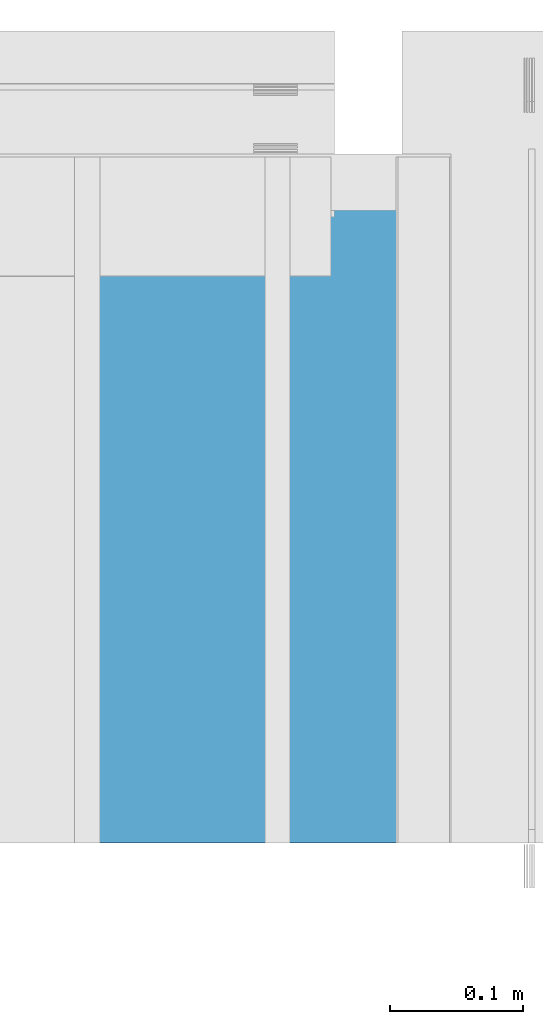
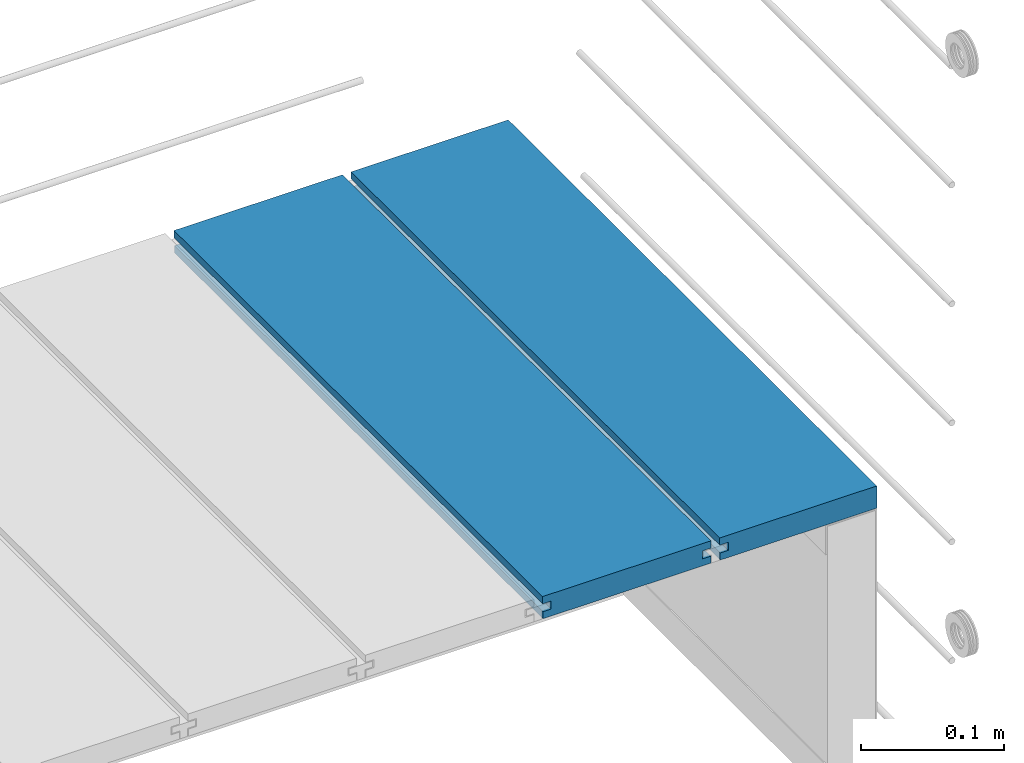
# One storey, part 24 of 33: 2 walls.
"""IFC4 building model written with IfcOpenShell, lengths in feet."""

import ifcopenshell
import ifcopenshell.guid

model = None  # the IFC model being written
_history = None  # IfcOwnerHistory: only IFC2X3 demands one
_inside = {}  # id of a spatial element -> (the spatial element, [elements in it])
_under = {}  # id of a project, library or spatial element -> (it, [spatial elements below it])
_declared = {}  # id of a project -> (the project, [libraries it declares])
_typed = {}  # id of a type object -> (the type object, [elements of that type])
_made_of = {}  # id of a material, layer set ... -> (it, [elements and type objects made of it])


def new_model(schema):
    """Start an empty IFC model of exactly this schema.

    Asked for "IFC4X3", IfcOpenShell would pick the latest addendum, in which some entities
    have other attributes; the version numbers below select the first issue.
    IFC2X3 requires an IfcOwnerHistory on every rooted entity: one is made here for all.
    """
    global model, _history
    if schema == "IFC4X3":
        model = ifcopenshell.file(schema_version=(4, 3, 0, 0))
    else:
        model = ifcopenshell.file(schema=schema)
    _inside.clear()
    _under.clear()
    _declared.clear()
    _typed.clear()
    _made_of.clear()
    _history = None
    if model.schema == "IFC2X3":
        org = make("IfcOrganization", Name="unknown")
        user = make(
            "IfcPersonAndOrganization",
            ThePerson=make("IfcPerson", FamilyName="unknown"),
            TheOrganization=org,
        )
        app = make(
            "IfcApplication",
            ApplicationDeveloper=org,
            Version="unknown",
            ApplicationFullName="unknown",
            ApplicationIdentifier="unknown",
        )
        _history = make(
            "IfcOwnerHistory",
            OwningUser=user,
            OwningApplication=app,
            ChangeAction="ADDED",
            CreationDate=0,
        )
    return model


def make(cls, **values):
    """One entity of the class cls with the attributes given. An attribute that is None is left unset."""
    return model.create_entity(
        cls, **{name: value for name, value in values.items() if value is not None}
    )


def entity(cls, *values):
    """Any entity or typed value of the class cls, its attributes in the order of the schema. None: left unset."""
    e = model.create_entity(cls)
    for i, value in enumerate(values):
        if value is not None:
            e[i] = value
    return e


def rooted(cls, **values):
    """An entity with a GlobalId (a new one), such as an element, a storey or a relation."""
    return make(cls, GlobalId=ifcopenshell.guid.new(), OwnerHistory=_history, **values)


def si_unit(unit_type, name, prefix=None):
    """IfcSIUnit, for example si_unit("LENGTHUNIT", "METRE", prefix="MILLI")."""
    return make("IfcSIUnit", UnitType=unit_type, Prefix=prefix, Name=name)


def converted_unit(unit_type, name, factor, base, dimensions=None, offset=None):
    """IfcConversionBasedUnit, such as the inch: factor (a typed value) times the base unit."""
    return make(
        "IfcConversionBasedUnit"
        if offset is None
        else "IfcConversionBasedUnitWithOffset",
        ConversionOffset=offset,
        Dimensions=None
        if dimensions is None
        else entity("IfcDimensionalExponents", *dimensions),
        UnitType=unit_type,
        Name=name,
        ConversionFactor=make(
            "IfcMeasureWithUnit", ValueComponent=factor, UnitComponent=base
        ),
    )


def derived_unit(unit_type, elements):
    """IfcDerivedUnit: a product of units, each with its exponent."""
    return make(
        "IfcDerivedUnit",
        Elements=[
            make("IfcDerivedUnitElement", Unit=unit, Exponent=power)
            for unit, power in elements
        ],
        UnitType=unit_type,
    )


def assignment(units):
    """IfcUnitAssignment: the units of a project."""
    return None if units is None else make("IfcUnitAssignment", Units=units)


def point(xyz):
    """IfcCartesianPoint."""
    return None if xyz is None else make("IfcCartesianPoint", Coordinates=xyz)


def direction(xyz):
    """IfcDirection."""
    return None if xyz is None else make("IfcDirection", DirectionRatios=xyz)


def frame(location, z_axis=None, x_axis=None):
    """IfcAxis2Placement3D, a coordinate frame: its origin and axes. An axis left out is left unset."""
    return make(
        "IfcAxis2Placement3D",
        Location=point(location),
        Axis=direction(z_axis),
        RefDirection=direction(x_axis),
    )


def origin():
    """The frame at (0, 0, 0) with its axes left unset."""
    return frame((0.0, 0.0, 0.0))


def place(relative_to, where):
    """IfcLocalPlacement: puts the frame where relative to a parent placement (None: the world)."""
    return make(
        "IfcLocalPlacement", PlacementRelTo=relative_to, RelativePlacement=where
    )


def context(
    kind, dimensions, precision=None, world=None, true_north=None, identifier=None
):
    """IfcGeometricRepresentationContext, for example the 3D "Model" context."""
    return make(
        "IfcGeometricRepresentationContext",
        ContextIdentifier=identifier,
        ContextType=kind,
        CoordinateSpaceDimension=dimensions,
        Precision=precision,
        WorldCoordinateSystem=world,
        TrueNorth=true_north,
    )


def subcontext(parent, identifier, kind, view, scale=None):
    """IfcGeometricRepresentationSubContext, for example "Body" below "Model"."""
    return make(
        "IfcGeometricRepresentationSubContext",
        ContextIdentifier=identifier,
        ContextType=kind,
        ParentContext=parent,
        TargetScale=scale,
        TargetView=view,
    )


def project(units=None, contexts=None):
    """IfcProject with its units and contexts."""
    return rooted(
        "IfcProject",
        Name="project",
        RepresentationContexts=contexts,
        UnitsInContext=assignment(units),
    )


def spatial(cls, under=None, at=None, **own):
    """A site, building, storey or space (cls), placed at a placement, below another one or the project."""
    s = rooted(cls, ObjectPlacement=at, **own)
    if under is not None:
        _under.setdefault(under.id(), (under, []))[1].append(s)
    return s


def shape(context_of_items, identifier, shape_type, items):
    """IfcShapeRepresentation: the items that make up one representation, for example the "Body"."""
    return make(
        "IfcShapeRepresentation",
        ContextOfItems=context_of_items,
        RepresentationIdentifier=identifier,
        RepresentationType=shape_type,
        Items=items,
    )


def material(Name=None, Category=None):
    """IfcMaterial."""
    return make("IfcMaterial", Name=Name, Category=Category)


def made_of(thing, what):
    """Note that an element or type object is made of a material, layer set ...; save() writes the relation."""
    if what is not None:
        _made_of.setdefault(what.id(), (what, []))[1].append(thing)
    return thing


def type_object(cls, material=None, **own):
    """A type object (cls), such as IfcWallType, which elements share."""
    return made_of(rooted(cls, **own), material)


def element(
    cls,
    number,
    at=None,
    inside=None,
    cuts=None,
    type_object=None,
    material=None,
    context=None,
    identifier="Body",
    shape_type=None,
    held_by="IfcProductDefinitionShape",
    body=None,
    shapes=None,
    **own,
):
    """One element of the class cls, such as IfcWall. Its Tag is "e" and its number.

    at: its placement. inside: the storey or other place that contains it. cuts: it is an
    opening in that element (IfcRelVoidsElement). A single representation is given by context,
    identifier, shape_type and body (its items); several are given by shapes. held_by: the class
    of the entity that holds the representations. save() writes the other relations.
    """
    e = rooted(cls, Tag="e%d" % number, ObjectPlacement=at, **own)
    if body is not None:
        shapes = [shape(context, identifier, shape_type, body)]
    if shapes is not None:
        e.Representation = make(held_by, Representations=shapes)
    if inside is not None:
        _inside.setdefault(inside.id(), (inside, []))[1].append(e)
    if cuts is not None:
        rooted(
            "IfcRelVoidsElement", RelatingBuildingElement=cuts, RelatedOpeningElement=e
        )
    if type_object is not None:
        _typed.setdefault(type_object.id(), (type_object, []))[1].append(e)
    return made_of(e, material)


def aggregate(whole, parts):
    """IfcRelAggregates: a whole, such as a stair, and the parts it consists of."""
    return rooted("IfcRelAggregates", RelatingObject=whole, RelatedObjects=parts)


def save(model, path):
    """Write the relations noted so far, then the file.

    IfcRelAggregates (storeys below a building ...), IfcRelContainedInSpatialStructure (elements
    in a storey), IfcRelDefinesByType, IfcRelAssociatesMaterial and IfcRelDeclares: one each for
    every whole, place, type object, material and project.
    """
    for whole, parts in _under.values():
        aggregate(whole, parts)
    for where, things in _inside.values():
        rooted(
            "IfcRelContainedInSpatialStructure",
            RelatedElements=things,
            RelatingStructure=where,
        )
    for kind, things in _typed.values():
        rooted("IfcRelDefinesByType", RelatedObjects=things, RelatingType=kind)
    for what, things in _made_of.values():
        rooted("IfcRelAssociatesMaterial", RelatedObjects=things, RelatingMaterial=what)
    for by, libraries in _declared.values():
        rooted("IfcRelDeclares", RelatingContext=by, RelatedDefinitions=libraries)
    model.write(path)


model = new_model("IFC4")

# Units and contexts
model_context = context("Model", 3, precision=0.0001, world=origin(), true_north=direction((6.12303176911189e-17, 1.0)))
body_context = subcontext(model_context, "Body", "Model", "MODEL_VIEW")
ifc_project = project(units=[converted_unit("LENGTHUNIT", "FOOT", entity("IfcRatioMeasure", 0.3048), si_unit("LENGTHUNIT", "METRE"), dimensions=[1, 0, 0, 0, 0, 0, 0]), converted_unit("AREAUNIT", "SQUARE FOOT", entity("IfcRatioMeasure", 0.09290304), si_unit("AREAUNIT", "SQUARE_METRE"), dimensions=[2, 0, 0, 0, 0, 0, 0]), converted_unit("VOLUMEUNIT", "CUBIC FOOT", entity("IfcRatioMeasure", 0.028316846592), si_unit("VOLUMEUNIT", "CUBIC_METRE"), dimensions=[3, 0, 0, 0, 0, 0, 0]), converted_unit("PLANEANGLEUNIT", "DEGREE", entity("IfcRatioMeasure", 0.0174532925199433), si_unit("PLANEANGLEUNIT", "RADIAN"), dimensions=[0, 0, 0, 0, 0, 0, 0]), si_unit("MASSUNIT", "GRAM", prefix="KILO"), derived_unit("MASSDENSITYUNIT", [(si_unit("MASSUNIT", "GRAM", prefix="KILO"), 1), (si_unit("LENGTHUNIT", "METRE"), -3)]), derived_unit("MOMENTOFINERTIAUNIT", [(si_unit("LENGTHUNIT", "METRE"), 4)]), si_unit("TIMEUNIT", "SECOND"), si_unit("FREQUENCYUNIT", "HERTZ"), si_unit("THERMODYNAMICTEMPERATUREUNIT", "DEGREE_CELSIUS"), derived_unit("THERMALTRANSMITTANCEUNIT", [(si_unit("MASSUNIT", "GRAM", prefix="KILO"), 1), (si_unit("THERMODYNAMICTEMPERATUREUNIT", "KELVIN"), -1), (si_unit("TIMEUNIT", "SECOND"), -3)]), derived_unit("VOLUMETRICFLOWRATEUNIT", [(si_unit("LENGTHUNIT", "METRE"), 3), (si_unit("TIMEUNIT", "SECOND"), -1)]), si_unit("ELECTRICCURRENTUNIT", "AMPERE"), si_unit("ELECTRICVOLTAGEUNIT", "VOLT"), si_unit("POWERUNIT", "WATT"), si_unit("FORCEUNIT", "NEWTON"), si_unit("ILLUMINANCEUNIT", "LUX"), si_unit("LUMINOUSFLUXUNIT", "LUMEN"), si_unit("LUMINOUSINTENSITYUNIT", "CANDELA"), derived_unit("USERDEFINED", [(si_unit("MASSUNIT", "GRAM", prefix="KILO"), -1), (si_unit("LENGTHUNIT", "METRE"), -2), (si_unit("TIMEUNIT", "SECOND"), 3), (si_unit("LUMINOUSFLUXUNIT", "LUMEN"), 1)]), derived_unit("LINEARVELOCITYUNIT", [(si_unit("LENGTHUNIT", "METRE"), 1), (si_unit("TIMEUNIT", "SECOND"), -1)]), si_unit("PRESSUREUNIT", "PASCAL"), derived_unit("USERDEFINED", [(si_unit("LENGTHUNIT", "METRE"), -2), (si_unit("MASSUNIT", "GRAM", prefix="KILO"), 1), (si_unit("TIMEUNIT", "SECOND"), -2)]), derived_unit("LINEARFORCEUNIT", [(si_unit("MASSUNIT", "GRAM", prefix="KILO"), 1), (si_unit("LENGTHUNIT", "METRE"), 1), (si_unit("TIMEUNIT", "SECOND"), -2), (si_unit("LENGTHUNIT", "METRE"), -1)]), derived_unit("PLANARFORCEUNIT", [(si_unit("MASSUNIT", "GRAM", prefix="KILO"), 1), (si_unit("LENGTHUNIT", "METRE"), 1), (si_unit("TIMEUNIT", "SECOND"), -2), (si_unit("LENGTHUNIT", "METRE"), -2)])], contexts=[model_context])

# Site, building, storey
site_placement = place(None, origin())
site = spatial("IfcSite", under=ifc_project, at=site_placement, CompositionType="ELEMENT")
building_placement = place(site_placement, origin())
building = spatial("IfcBuilding", under=site, at=building_placement, CompositionType="ELEMENT")
storey_placement = place(building_placement, frame((0.0, 0.0, 10.0)))
storey = spatial("IfcBuildingStorey", under=building, at=storey_placement, Name="2ND FLOOR", CompositionType="ELEMENT", Elevation=10.0000000000002)

# Walls
ifc_material = material(Name="COMPOSITE DECKING W/ HIDDEN FASTENERS", Category="Materials")
wall_type_1 = type_object("IfcWallType", Name="Generic Models 638:Generic Models 1", PredefinedType="NOTDEFINED", material=ifc_material)
wall_1_placement = place(storey_placement, frame((1493.41048805286, 3.0461139299927, 0.682902157150137), z_axis=(0.0, 0.0, 1.0), x_axis=(0.0, 1.0, 0.0)))
cartesian_point_1 = entity("IfcCartesianPoint", [1.69226081335874, -0.446740923891412, 0.0])
vertex_point_1 = entity("IfcVertexPoint", cartesian_point_1)
cartesian_point_2 = entity("IfcCartesianPoint", [1.69226081335874, -0.00132475379450625, 0.0])
vertex_point_2 = entity("IfcVertexPoint", cartesian_point_2)
ifc_direction_1 = entity("IfcDirection", [0.0, 1.0, 0.0])
edge_curve_1 = entity("IfcEdgeCurve", vertex_point_1, vertex_point_2, entity("IfcTrimmedCurve", entity("IfcLine", cartesian_point_1, entity("IfcVector", ifc_direction_1, 1.0)), [cartesian_point_1], [cartesian_point_2], True, "CARTESIAN"), True)
cartesian_point_3 = entity("IfcCartesianPoint", [1.69226081335874, -0.00132475379450625, 0.0198779960861479])
vertex_point_3 = entity("IfcVertexPoint", cartesian_point_3)
ifc_direction_2 = entity("IfcDirection", [0.0, 0.0, 1.0])
edge_curve_2 = entity("IfcEdgeCurve", vertex_point_2, vertex_point_3, entity("IfcTrimmedCurve", entity("IfcLine", cartesian_point_2, entity("IfcVector", ifc_direction_2, 1.0)), [cartesian_point_2], [cartesian_point_3], True, "CARTESIAN"), True)
cartesian_point_4 = entity("IfcCartesianPoint", [1.69226081335874, -0.0228400010807945, 0.0198779960861479])
vertex_point_4 = entity("IfcVertexPoint", cartesian_point_4)
ifc_direction_3 = entity("IfcDirection", [0.0, -1.0, 0.0])
edge_curve_3 = entity("IfcEdgeCurve", vertex_point_3, vertex_point_4, entity("IfcTrimmedCurve", entity("IfcLine", cartesian_point_3, entity("IfcVector", ifc_direction_3, 1.0)), [cartesian_point_3], [cartesian_point_4], True, "CARTESIAN"), True)
cartesian_point_5 = entity("IfcCartesianPoint", [1.69226081335874, -0.0228400010807945, 0.0422987663426522])
vertex_point_5 = entity("IfcVertexPoint", cartesian_point_5)
edge_curve_4 = entity("IfcEdgeCurve", vertex_point_4, vertex_point_5, entity("IfcTrimmedCurve", entity("IfcLine", cartesian_point_4, entity("IfcVector", ifc_direction_2, 1.0)), [cartesian_point_4], [cartesian_point_5], True, "CARTESIAN"), True)
cartesian_point_6 = entity("IfcCartesianPoint", [1.69226081335874, 0.0, 0.0422987663426522])
vertex_point_6 = entity("IfcVertexPoint", cartesian_point_6)
edge_curve_5 = entity("IfcEdgeCurve", vertex_point_5, vertex_point_6, entity("IfcTrimmedCurve", entity("IfcLine", cartesian_point_5, entity("IfcVector", ifc_direction_1, 1.0)), [cartesian_point_5], [cartesian_point_6], True, "CARTESIAN"), True)
cartesian_point_7 = entity("IfcCartesianPoint", [1.69226081335874, 0.0, 0.0625000000000551])
vertex_point_7 = entity("IfcVertexPoint", cartesian_point_7)
edge_curve_6 = entity("IfcEdgeCurve", vertex_point_6, vertex_point_7, entity("IfcTrimmedCurve", entity("IfcLine", cartesian_point_6, entity("IfcVector", ifc_direction_2, 1.0)), [cartesian_point_6], [cartesian_point_7], True, "CARTESIAN"), True)
cartesian_point_8 = entity("IfcCartesianPoint", [1.69226081335874, -0.446740923891639, 0.0625])
vertex_point_8 = entity("IfcVertexPoint", cartesian_point_8)
edge_curve_7 = entity("IfcEdgeCurve", vertex_point_7, vertex_point_8, entity("IfcTrimmedCurve", entity("IfcLine", cartesian_point_7, entity("IfcVector", ifc_direction_3, 1.0)), [cartesian_point_7], [cartesian_point_8], True, "CARTESIAN"), True)
cartesian_point_9 = entity("IfcCartesianPoint", [1.69226081335874, -0.446740923891639, 0.0422987663426522])
vertex_point_9 = entity("IfcVertexPoint", cartesian_point_9)
ifc_direction_4 = entity("IfcDirection", [0.0, 0.0, -1.0])
edge_curve_8 = entity("IfcEdgeCurve", vertex_point_8, vertex_point_9, entity("IfcTrimmedCurve", entity("IfcLine", cartesian_point_8, entity("IfcVector", ifc_direction_4, 1.0)), [cartesian_point_8], [cartesian_point_9], True, "CARTESIAN"), True)
cartesian_point_10 = entity("IfcCartesianPoint", [1.69226081335874, -0.423900922810617, 0.0422987663426522])
vertex_point_10 = entity("IfcVertexPoint", cartesian_point_10)
edge_curve_9 = entity("IfcEdgeCurve", vertex_point_9, vertex_point_10, entity("IfcTrimmedCurve", entity("IfcLine", cartesian_point_9, entity("IfcVector", ifc_direction_1, 1.0)), [cartesian_point_9], [cartesian_point_10], True, "CARTESIAN"), True)
cartesian_point_11 = entity("IfcCartesianPoint", [1.69226081335874, -0.423900922810617, 0.0198779960861479])
vertex_point_11 = entity("IfcVertexPoint", cartesian_point_11)
edge_curve_10 = entity("IfcEdgeCurve", vertex_point_10, vertex_point_11, entity("IfcTrimmedCurve", entity("IfcLine", cartesian_point_10, entity("IfcVector", ifc_direction_4, 1.0)), [cartesian_point_10], [cartesian_point_11], True, "CARTESIAN"), True)
cartesian_point_12 = entity("IfcCartesianPoint", [1.69226081335874, -0.446740923891412, 0.0198779960861479])
vertex_point_12 = entity("IfcVertexPoint", cartesian_point_12)
edge_curve_11 = entity("IfcEdgeCurve", vertex_point_11, vertex_point_12, entity("IfcTrimmedCurve", entity("IfcLine", cartesian_point_11, entity("IfcVector", ifc_direction_3, 1.0)), [cartesian_point_11], [cartesian_point_12], True, "CARTESIAN"), True)
edge_curve_12 = entity("IfcEdgeCurve", vertex_point_12, vertex_point_1, entity("IfcTrimmedCurve", entity("IfcLine", cartesian_point_12, entity("IfcVector", ifc_direction_4, 1.0)), [cartesian_point_12], [cartesian_point_1], True, "CARTESIAN"), True)
ifc_direction_5 = entity("IfcDirection", [1.0, 0.0, 0.0])
cartesian_point_13 = entity("IfcCartesianPoint", [0.0, -0.446740923891412, 0.0])
vertex_point_13 = entity("IfcVertexPoint", cartesian_point_13)
cartesian_point_14 = entity("IfcCartesianPoint", [0.0, -0.446740923891412, 0.0198779960861479])
vertex_point_14 = entity("IfcVertexPoint", cartesian_point_14)
edge_curve_13 = entity("IfcEdgeCurve", vertex_point_13, vertex_point_14, entity("IfcTrimmedCurve", entity("IfcLine", cartesian_point_13, entity("IfcVector", ifc_direction_2, 1.0)), [cartesian_point_13], [cartesian_point_14], True, "CARTESIAN"), True)
cartesian_point_15 = entity("IfcCartesianPoint", [0.0, -0.423900922810617, 0.0198779960861479])
vertex_point_15 = entity("IfcVertexPoint", cartesian_point_15)
edge_curve_14 = entity("IfcEdgeCurve", vertex_point_14, vertex_point_15, entity("IfcTrimmedCurve", entity("IfcLine", cartesian_point_14, entity("IfcVector", ifc_direction_1, 1.0)), [cartesian_point_14], [cartesian_point_15], True, "CARTESIAN"), True)
cartesian_point_16 = entity("IfcCartesianPoint", [0.0, -0.423900922810617, 0.0422987663426522])
vertex_point_16 = entity("IfcVertexPoint", cartesian_point_16)
edge_curve_15 = entity("IfcEdgeCurve", vertex_point_15, vertex_point_16, entity("IfcTrimmedCurve", entity("IfcLine", cartesian_point_15, entity("IfcVector", ifc_direction_2, 1.0)), [cartesian_point_15], [cartesian_point_16], True, "CARTESIAN"), True)
cartesian_point_17 = entity("IfcCartesianPoint", [0.0, -0.446740923891639, 0.0422987663426522])
vertex_point_17 = entity("IfcVertexPoint", cartesian_point_17)
edge_curve_16 = entity("IfcEdgeCurve", vertex_point_16, vertex_point_17, entity("IfcTrimmedCurve", entity("IfcLine", cartesian_point_16, entity("IfcVector", ifc_direction_3, 1.0)), [cartesian_point_16], [cartesian_point_17], True, "CARTESIAN"), True)
cartesian_point_18 = entity("IfcCartesianPoint", [0.0, -0.446740923891639, 0.0625])
vertex_point_18 = entity("IfcVertexPoint", cartesian_point_18)
edge_curve_17 = entity("IfcEdgeCurve", vertex_point_17, vertex_point_18, entity("IfcTrimmedCurve", entity("IfcLine", cartesian_point_17, entity("IfcVector", ifc_direction_2, 1.0)), [cartesian_point_17], [cartesian_point_18], True, "CARTESIAN"), True)
cartesian_point_19 = entity("IfcCartesianPoint", [0.0, 0.0, 0.0625000000000551])
vertex_point_19 = entity("IfcVertexPoint", cartesian_point_19)
edge_curve_18 = entity("IfcEdgeCurve", vertex_point_18, vertex_point_19, entity("IfcTrimmedCurve", entity("IfcLine", cartesian_point_18, entity("IfcVector", ifc_direction_1, 1.0)), [cartesian_point_18], [cartesian_point_19], True, "CARTESIAN"), True)
cartesian_point_20 = entity("IfcCartesianPoint", [0.0, 0.0, 0.0422987663426522])
vertex_point_20 = entity("IfcVertexPoint", cartesian_point_20)
edge_curve_19 = entity("IfcEdgeCurve", vertex_point_19, vertex_point_20, entity("IfcTrimmedCurve", entity("IfcLine", cartesian_point_19, entity("IfcVector", ifc_direction_4, 1.0)), [cartesian_point_19], [cartesian_point_20], True, "CARTESIAN"), True)
cartesian_point_21 = entity("IfcCartesianPoint", [0.0, -0.0228400010807945, 0.0422987663426522])
vertex_point_21 = entity("IfcVertexPoint", cartesian_point_21)
edge_curve_20 = entity("IfcEdgeCurve", vertex_point_20, vertex_point_21, entity("IfcTrimmedCurve", entity("IfcLine", cartesian_point_20, entity("IfcVector", ifc_direction_3, 1.0)), [cartesian_point_20], [cartesian_point_21], True, "CARTESIAN"), True)
cartesian_point_22 = entity("IfcCartesianPoint", [0.0, -0.0228400010807945, 0.0198779960861479])
vertex_point_22 = entity("IfcVertexPoint", cartesian_point_22)
edge_curve_21 = entity("IfcEdgeCurve", vertex_point_21, vertex_point_22, entity("IfcTrimmedCurve", entity("IfcLine", cartesian_point_21, entity("IfcVector", ifc_direction_4, 1.0)), [cartesian_point_21], [cartesian_point_22], True, "CARTESIAN"), True)
cartesian_point_23 = entity("IfcCartesianPoint", [0.0, -0.00132475379450625, 0.0198779960861479])
vertex_point_23 = entity("IfcVertexPoint", cartesian_point_23)
edge_curve_22 = entity("IfcEdgeCurve", vertex_point_22, vertex_point_23, entity("IfcTrimmedCurve", entity("IfcLine", cartesian_point_22, entity("IfcVector", ifc_direction_1, 1.0)), [cartesian_point_22], [cartesian_point_23], True, "CARTESIAN"), True)
cartesian_point_24 = entity("IfcCartesianPoint", [0.0, -0.00132475379450625, 0.0])
vertex_point_24 = entity("IfcVertexPoint", cartesian_point_24)
edge_curve_23 = entity("IfcEdgeCurve", vertex_point_23, vertex_point_24, entity("IfcTrimmedCurve", entity("IfcLine", cartesian_point_23, entity("IfcVector", ifc_direction_4, 1.0)), [cartesian_point_23], [cartesian_point_24], True, "CARTESIAN"), True)
edge_curve_24 = entity("IfcEdgeCurve", vertex_point_24, vertex_point_13, entity("IfcTrimmedCurve", entity("IfcLine", cartesian_point_24, entity("IfcVector", ifc_direction_3, 1.0)), [cartesian_point_24], [cartesian_point_13], True, "CARTESIAN"), True)
ifc_direction_6 = entity("IfcDirection", [-1.0, 0.0, 0.0])
edge_curve_25 = entity("IfcEdgeCurve", vertex_point_13, vertex_point_1, entity("IfcTrimmedCurve", entity("IfcLine", cartesian_point_13, entity("IfcVector", ifc_direction_5, 1.0)), [cartesian_point_13], [cartesian_point_1], True, "CARTESIAN"), True)
edge_curve_26 = entity("IfcEdgeCurve", vertex_point_12, vertex_point_14, entity("IfcTrimmedCurve", entity("IfcLine", cartesian_point_14, entity("IfcVector", ifc_direction_6, 1.0)), [cartesian_point_12], [cartesian_point_14], True, "CARTESIAN"), True)
edge_curve_27 = entity("IfcEdgeCurve", vertex_point_18, vertex_point_8, entity("IfcTrimmedCurve", entity("IfcLine", cartesian_point_18, entity("IfcVector", ifc_direction_5, 1.0)), [cartesian_point_18], [cartesian_point_8], True, "CARTESIAN"), True)
edge_curve_28 = entity("IfcEdgeCurve", vertex_point_7, vertex_point_19, entity("IfcTrimmedCurve", entity("IfcLine", cartesian_point_19, entity("IfcVector", ifc_direction_6, 1.0)), [cartesian_point_7], [cartesian_point_19], True, "CARTESIAN"), True)
edge_curve_29 = entity("IfcEdgeCurve", vertex_point_6, vertex_point_20, entity("IfcTrimmedCurve", entity("IfcLine", cartesian_point_20, entity("IfcVector", ifc_direction_6, 1.0)), [cartesian_point_6], [cartesian_point_20], True, "CARTESIAN"), True)
edge_curve_30 = entity("IfcEdgeCurve", vertex_point_24, vertex_point_2, entity("IfcTrimmedCurve", entity("IfcLine", cartesian_point_24, entity("IfcVector", ifc_direction_5, 1.0)), [cartesian_point_24], [cartesian_point_2], True, "CARTESIAN"), True)
edge_curve_31 = entity("IfcEdgeCurve", vertex_point_17, vertex_point_9, entity("IfcTrimmedCurve", entity("IfcLine", cartesian_point_17, entity("IfcVector", ifc_direction_5, 1.0)), [cartesian_point_17], [cartesian_point_9], True, "CARTESIAN"), True)
edge_curve_32 = entity("IfcEdgeCurve", vertex_point_5, vertex_point_21, entity("IfcTrimmedCurve", entity("IfcLine", cartesian_point_21, entity("IfcVector", ifc_direction_6, 1.0)), [cartesian_point_5], [cartesian_point_21], True, "CARTESIAN"), True)
edge_curve_33 = entity("IfcEdgeCurve", vertex_point_4, vertex_point_22, entity("IfcTrimmedCurve", entity("IfcLine", cartesian_point_22, entity("IfcVector", ifc_direction_6, 1.0)), [cartesian_point_4], [cartesian_point_22], True, "CARTESIAN"), True)
edge_curve_34 = entity("IfcEdgeCurve", vertex_point_3, vertex_point_23, entity("IfcTrimmedCurve", entity("IfcLine", cartesian_point_23, entity("IfcVector", ifc_direction_6, 1.0)), [cartesian_point_3], [cartesian_point_23], True, "CARTESIAN"), True)
edge_curve_35 = entity("IfcEdgeCurve", vertex_point_11, vertex_point_15, entity("IfcTrimmedCurve", entity("IfcLine", cartesian_point_15, entity("IfcVector", ifc_direction_6, 1.0)), [cartesian_point_11], [cartesian_point_15], True, "CARTESIAN"), True)
edge_curve_36 = entity("IfcEdgeCurve", vertex_point_10, vertex_point_16, entity("IfcTrimmedCurve", entity("IfcLine", cartesian_point_16, entity("IfcVector", ifc_direction_6, 1.0)), [cartesian_point_10], [cartesian_point_16], True, "CARTESIAN"), True)
element("IfcWall", 1, at=wall_1_placement, inside=storey, type_object=wall_type_1, material=ifc_material, Name="Generic Models 638:Generic Models 1", ObjectType="Generic Models 638:Generic Models 1", PredefinedType="NOTDEFINED", context=body_context, shape_type="AdvancedBrep", body=[
    entity("IfcAdvancedBrep", entity("IfcClosedShell", [entity("IfcAdvancedFace", [entity("IfcFaceOuterBound", entity("IfcEdgeLoop", [entity("IfcOrientedEdge", None, None, edge_curve_1, True), entity("IfcOrientedEdge", None, None, edge_curve_2, True), entity("IfcOrientedEdge", None, None, edge_curve_3, True), entity("IfcOrientedEdge", None, None, edge_curve_4, True), entity("IfcOrientedEdge", None, None, edge_curve_5, True), entity("IfcOrientedEdge", None, None, edge_curve_6, True), entity("IfcOrientedEdge", None, None, edge_curve_7, True), entity("IfcOrientedEdge", None, None, edge_curve_8, True), entity("IfcOrientedEdge", None, None, edge_curve_9, True), entity("IfcOrientedEdge", None, None, edge_curve_10, True), entity("IfcOrientedEdge", None, None, edge_curve_11, True), entity("IfcOrientedEdge", None, None, edge_curve_12, True)]), True)], entity("IfcPlane", entity("IfcAxis2Placement3D", entity("IfcCartesianPoint", [1.69226081335874, -0.446740923891412, -0.0208333333328241]), ifc_direction_5, ifc_direction_4)), True), entity("IfcAdvancedFace", [entity("IfcFaceOuterBound", entity("IfcEdgeLoop", [entity("IfcOrientedEdge", None, None, edge_curve_13, True), entity("IfcOrientedEdge", None, None, edge_curve_14, True), entity("IfcOrientedEdge", None, None, edge_curve_15, True), entity("IfcOrientedEdge", None, None, edge_curve_16, True), entity("IfcOrientedEdge", None, None, edge_curve_17, True), entity("IfcOrientedEdge", None, None, edge_curve_18, True), entity("IfcOrientedEdge", None, None, edge_curve_19, True), entity("IfcOrientedEdge", None, None, edge_curve_20, True), entity("IfcOrientedEdge", None, None, edge_curve_21, True), entity("IfcOrientedEdge", None, None, edge_curve_22, True), entity("IfcOrientedEdge", None, None, edge_curve_23, True), entity("IfcOrientedEdge", None, None, edge_curve_24, True)]), True)], entity("IfcPlane", entity("IfcAxis2Placement3D", entity("IfcCartesianPoint", [0.0, -0.446740923891412, -0.0208333333328241]), ifc_direction_6, ifc_direction_2)), True), entity("IfcAdvancedFace", [entity("IfcFaceOuterBound", entity("IfcEdgeLoop", [entity("IfcOrientedEdge", None, None, edge_curve_13, False), entity("IfcOrientedEdge", None, None, edge_curve_25, True), entity("IfcOrientedEdge", None, None, edge_curve_12, False), entity("IfcOrientedEdge", None, None, edge_curve_26, True)]), True)], entity("IfcPlane", entity("IfcAxis2Placement3D", cartesian_point_13, ifc_direction_3, ifc_direction_5)), True), entity("IfcAdvancedFace", [entity("IfcFaceOuterBound", entity("IfcEdgeLoop", [entity("IfcOrientedEdge", None, None, edge_curve_18, False), entity("IfcOrientedEdge", None, None, edge_curve_27, True), entity("IfcOrientedEdge", None, None, edge_curve_7, False), entity("IfcOrientedEdge", None, None, edge_curve_28, True)]), True)], entity("IfcPlane", entity("IfcAxis2Placement3D", cartesian_point_18, ifc_direction_2, ifc_direction_5)), True), entity("IfcAdvancedFace", [entity("IfcFaceOuterBound", entity("IfcEdgeLoop", [entity("IfcOrientedEdge", None, None, edge_curve_19, False), entity("IfcOrientedEdge", None, None, edge_curve_28, False), entity("IfcOrientedEdge", None, None, edge_curve_6, False), entity("IfcOrientedEdge", None, None, edge_curve_29, True)]), True)], entity("IfcPlane", entity("IfcAxis2Placement3D", cartesian_point_19, ifc_direction_1, ifc_direction_5)), True), entity("IfcAdvancedFace", [entity("IfcFaceOuterBound", entity("IfcEdgeLoop", [entity("IfcOrientedEdge", None, None, edge_curve_24, False), entity("IfcOrientedEdge", None, None, edge_curve_30, True), entity("IfcOrientedEdge", None, None, edge_curve_1, False), entity("IfcOrientedEdge", None, None, edge_curve_25, False)]), True)], entity("IfcPlane", entity("IfcAxis2Placement3D", cartesian_point_24, ifc_direction_4, ifc_direction_5)), True), entity("IfcAdvancedFace", [entity("IfcFaceOuterBound", entity("IfcEdgeLoop", [entity("IfcOrientedEdge", None, None, edge_curve_17, False), entity("IfcOrientedEdge", None, None, edge_curve_31, True), entity("IfcOrientedEdge", None, None, edge_curve_8, False), entity("IfcOrientedEdge", None, None, edge_curve_27, False)]), True)], entity("IfcPlane", entity("IfcAxis2Placement3D", cartesian_point_17, ifc_direction_3, ifc_direction_5)), True), entity("IfcAdvancedFace", [entity("IfcFaceOuterBound", entity("IfcEdgeLoop", [entity("IfcOrientedEdge", None, None, edge_curve_20, False), entity("IfcOrientedEdge", None, None, edge_curve_29, False), entity("IfcOrientedEdge", None, None, edge_curve_5, False), entity("IfcOrientedEdge", None, None, edge_curve_32, True)]), True)], entity("IfcPlane", entity("IfcAxis2Placement3D", cartesian_point_20, ifc_direction_4, ifc_direction_5)), True), entity("IfcAdvancedFace", [entity("IfcFaceOuterBound", entity("IfcEdgeLoop", [entity("IfcOrientedEdge", None, None, edge_curve_21, False), entity("IfcOrientedEdge", None, None, edge_curve_32, False), entity("IfcOrientedEdge", None, None, edge_curve_4, False), entity("IfcOrientedEdge", None, None, edge_curve_33, True)]), True)], entity("IfcPlane", entity("IfcAxis2Placement3D", cartesian_point_21, ifc_direction_1, ifc_direction_5)), True), entity("IfcAdvancedFace", [entity("IfcFaceOuterBound", entity("IfcEdgeLoop", [entity("IfcOrientedEdge", None, None, edge_curve_22, False), entity("IfcOrientedEdge", None, None, edge_curve_33, False), entity("IfcOrientedEdge", None, None, edge_curve_3, False), entity("IfcOrientedEdge", None, None, edge_curve_34, True)]), True)], entity("IfcPlane", entity("IfcAxis2Placement3D", cartesian_point_22, ifc_direction_2, ifc_direction_5)), True), entity("IfcAdvancedFace", [entity("IfcFaceOuterBound", entity("IfcEdgeLoop", [entity("IfcOrientedEdge", None, None, edge_curve_23, False), entity("IfcOrientedEdge", None, None, edge_curve_34, False), entity("IfcOrientedEdge", None, None, edge_curve_2, False), entity("IfcOrientedEdge", None, None, edge_curve_30, False)]), True)], entity("IfcPlane", entity("IfcAxis2Placement3D", cartesian_point_23, ifc_direction_1, ifc_direction_5)), True), entity("IfcAdvancedFace", [entity("IfcFaceOuterBound", entity("IfcEdgeLoop", [entity("IfcOrientedEdge", None, None, edge_curve_14, False), entity("IfcOrientedEdge", None, None, edge_curve_26, False), entity("IfcOrientedEdge", None, None, edge_curve_11, False), entity("IfcOrientedEdge", None, None, edge_curve_35, True)]), True)], entity("IfcPlane", entity("IfcAxis2Placement3D", cartesian_point_14, ifc_direction_2, ifc_direction_5)), True), entity("IfcAdvancedFace", [entity("IfcFaceOuterBound", entity("IfcEdgeLoop", [entity("IfcOrientedEdge", None, None, edge_curve_15, False), entity("IfcOrientedEdge", None, None, edge_curve_35, False), entity("IfcOrientedEdge", None, None, edge_curve_10, False), entity("IfcOrientedEdge", None, None, edge_curve_36, True)]), True)], entity("IfcPlane", entity("IfcAxis2Placement3D", cartesian_point_15, ifc_direction_3, ifc_direction_5)), True), entity("IfcAdvancedFace", [entity("IfcFaceOuterBound", entity("IfcEdgeLoop", [entity("IfcOrientedEdge", None, None, edge_curve_16, False), entity("IfcOrientedEdge", None, None, edge_curve_36, False), entity("IfcOrientedEdge", None, None, edge_curve_9, False), entity("IfcOrientedEdge", None, None, edge_curve_31, False)]), True)], entity("IfcPlane", entity("IfcAxis2Placement3D", cartesian_point_16, ifc_direction_4, ifc_direction_5)), True)])),
])
wall_type_2 = type_object("IfcWallType", Name="Generic Models 643:Generic Models 1", PredefinedType="NOTDEFINED", material=ifc_material)
wall_2_placement = place(storey_placement, frame((1493.88025435495, 3.04611392999268, 0.682902157150137), z_axis=(0.0, 0.0, 1.0), x_axis=(0.0, 1.0, 0.0)))
cartesian_point_25 = entity("IfcCartesianPoint", [1.69226081335876, -0.416522210434323, 0.0])
vertex_point_25 = entity("IfcVertexPoint", cartesian_point_25)
cartesian_point_26 = entity("IfcCartesianPoint", [1.69226081335876, -0.00132475379450625, 0.0])
vertex_point_26 = entity("IfcVertexPoint", cartesian_point_26)
ifc_direction_7 = entity("IfcDirection", [0.0, 1.0, 0.0])
edge_curve_37 = entity("IfcEdgeCurve", vertex_point_25, vertex_point_26, entity("IfcTrimmedCurve", entity("IfcLine", cartesian_point_25, entity("IfcVector", ifc_direction_7, 1.0)), [cartesian_point_25], [cartesian_point_26], True, "CARTESIAN"), True)
cartesian_point_27 = entity("IfcCartesianPoint", [1.69226081335876, -0.00132475379450625, 0.0198779960861444])
vertex_point_27 = entity("IfcVertexPoint", cartesian_point_27)
ifc_direction_8 = entity("IfcDirection", [0.0, 0.0, 1.0])
edge_curve_38 = entity("IfcEdgeCurve", vertex_point_26, vertex_point_27, entity("IfcTrimmedCurve", entity("IfcLine", cartesian_point_26, entity("IfcVector", ifc_direction_8, 1.0)), [cartesian_point_26], [cartesian_point_27], True, "CARTESIAN"), True)
cartesian_point_28 = entity("IfcCartesianPoint", [1.69226081335876, -0.0228400010807945, 0.0198779960861444])
vertex_point_28 = entity("IfcVertexPoint", cartesian_point_28)
ifc_direction_9 = entity("IfcDirection", [0.0, -1.0, 0.0])
edge_curve_39 = entity("IfcEdgeCurve", vertex_point_27, vertex_point_28, entity("IfcTrimmedCurve", entity("IfcLine", cartesian_point_27, entity("IfcVector", ifc_direction_9, 1.0)), [cartesian_point_27], [cartesian_point_28], True, "CARTESIAN"), True)
cartesian_point_29 = entity("IfcCartesianPoint", [1.69226081335876, -0.0228400010807945, 0.0422987663426486])
vertex_point_29 = entity("IfcVertexPoint", cartesian_point_29)
edge_curve_40 = entity("IfcEdgeCurve", vertex_point_28, vertex_point_29, entity("IfcTrimmedCurve", entity("IfcLine", cartesian_point_28, entity("IfcVector", ifc_direction_8, 1.0)), [cartesian_point_28], [cartesian_point_29], True, "CARTESIAN"), True)
cartesian_point_30 = entity("IfcCartesianPoint", [1.69226081335876, 0.0, 0.0422987663426486])
vertex_point_30 = entity("IfcVertexPoint", cartesian_point_30)
edge_curve_41 = entity("IfcEdgeCurve", vertex_point_29, vertex_point_30, entity("IfcTrimmedCurve", entity("IfcLine", cartesian_point_29, entity("IfcVector", ifc_direction_7, 1.0)), [cartesian_point_29], [cartesian_point_30], True, "CARTESIAN"), True)
cartesian_point_31 = entity("IfcCartesianPoint", [1.69226081335876, 0.0, 0.0625000000000515])
vertex_point_31 = entity("IfcVertexPoint", cartesian_point_31)
edge_curve_42 = entity("IfcEdgeCurve", vertex_point_30, vertex_point_31, entity("IfcTrimmedCurve", entity("IfcLine", cartesian_point_30, entity("IfcVector", ifc_direction_8, 1.0)), [cartesian_point_30], [cartesian_point_31], True, "CARTESIAN"), True)
cartesian_point_32 = entity("IfcCartesianPoint", [1.69226081335876, -0.416522210434323, 0.0625])
vertex_point_32 = entity("IfcVertexPoint", cartesian_point_32)
edge_curve_43 = entity("IfcEdgeCurve", vertex_point_31, vertex_point_32, entity("IfcTrimmedCurve", entity("IfcLine", cartesian_point_31, entity("IfcVector", ifc_direction_9, 1.0)), [cartesian_point_31], [cartesian_point_32], True, "CARTESIAN"), True)
ifc_direction_10 = entity("IfcDirection", [0.0, 0.0, -1.0])
edge_curve_44 = entity("IfcEdgeCurve", vertex_point_32, vertex_point_25, entity("IfcTrimmedCurve", entity("IfcLine", cartesian_point_32, entity("IfcVector", ifc_direction_10, 1.0)), [cartesian_point_32], [cartesian_point_25], True, "CARTESIAN"), True)
ifc_direction_11 = entity("IfcDirection", [1.0, 0.0, 0.0])
cartesian_point_33 = entity("IfcCartesianPoint", [0.0, -0.416522210434323, 0.0])
vertex_point_33 = entity("IfcVertexPoint", cartesian_point_33)
cartesian_point_34 = entity("IfcCartesianPoint", [0.0, -0.416522210434323, 0.0625])
vertex_point_34 = entity("IfcVertexPoint", cartesian_point_34)
edge_curve_45 = entity("IfcEdgeCurve", vertex_point_33, vertex_point_34, entity("IfcTrimmedCurve", entity("IfcLine", cartesian_point_33, entity("IfcVector", ifc_direction_8, 1.0)), [cartesian_point_33], [cartesian_point_34], True, "CARTESIAN"), True)
cartesian_point_35 = entity("IfcCartesianPoint", [0.0, 0.0, 0.0625000000000515])
vertex_point_35 = entity("IfcVertexPoint", cartesian_point_35)
edge_curve_46 = entity("IfcEdgeCurve", vertex_point_34, vertex_point_35, entity("IfcTrimmedCurve", entity("IfcLine", cartesian_point_34, entity("IfcVector", ifc_direction_7, 1.0)), [cartesian_point_34], [cartesian_point_35], True, "CARTESIAN"), True)
cartesian_point_36 = entity("IfcCartesianPoint", [0.0, 0.0, 0.0422987663426486])
vertex_point_36 = entity("IfcVertexPoint", cartesian_point_36)
edge_curve_47 = entity("IfcEdgeCurve", vertex_point_35, vertex_point_36, entity("IfcTrimmedCurve", entity("IfcLine", cartesian_point_35, entity("IfcVector", ifc_direction_10, 1.0)), [cartesian_point_35], [cartesian_point_36], True, "CARTESIAN"), True)
cartesian_point_37 = entity("IfcCartesianPoint", [0.0, -0.0228400010807945, 0.0422987663426486])
vertex_point_37 = entity("IfcVertexPoint", cartesian_point_37)
edge_curve_48 = entity("IfcEdgeCurve", vertex_point_36, vertex_point_37, entity("IfcTrimmedCurve", entity("IfcLine", cartesian_point_36, entity("IfcVector", ifc_direction_9, 1.0)), [cartesian_point_36], [cartesian_point_37], True, "CARTESIAN"), True)
cartesian_point_38 = entity("IfcCartesianPoint", [0.0, -0.0228400010807945, 0.0198779960861444])
vertex_point_38 = entity("IfcVertexPoint", cartesian_point_38)
edge_curve_49 = entity("IfcEdgeCurve", vertex_point_37, vertex_point_38, entity("IfcTrimmedCurve", entity("IfcLine", cartesian_point_37, entity("IfcVector", ifc_direction_10, 1.0)), [cartesian_point_37], [cartesian_point_38], True, "CARTESIAN"), True)
cartesian_point_39 = entity("IfcCartesianPoint", [0.0, -0.00132475379450625, 0.0198779960861444])
vertex_point_39 = entity("IfcVertexPoint", cartesian_point_39)
edge_curve_50 = entity("IfcEdgeCurve", vertex_point_38, vertex_point_39, entity("IfcTrimmedCurve", entity("IfcLine", cartesian_point_38, entity("IfcVector", ifc_direction_7, 1.0)), [cartesian_point_38], [cartesian_point_39], True, "CARTESIAN"), True)
cartesian_point_40 = entity("IfcCartesianPoint", [0.0, -0.00132475379450625, 0.0])
vertex_point_40 = entity("IfcVertexPoint", cartesian_point_40)
edge_curve_51 = entity("IfcEdgeCurve", vertex_point_39, vertex_point_40, entity("IfcTrimmedCurve", entity("IfcLine", cartesian_point_39, entity("IfcVector", ifc_direction_10, 1.0)), [cartesian_point_39], [cartesian_point_40], True, "CARTESIAN"), True)
edge_curve_52 = entity("IfcEdgeCurve", vertex_point_40, vertex_point_33, entity("IfcTrimmedCurve", entity("IfcLine", cartesian_point_40, entity("IfcVector", ifc_direction_9, 1.0)), [cartesian_point_40], [cartesian_point_33], True, "CARTESIAN"), True)
ifc_direction_12 = entity("IfcDirection", [-1.0, 0.0, 0.0])
edge_curve_53 = entity("IfcEdgeCurve", vertex_point_34, vertex_point_32, entity("IfcTrimmedCurve", entity("IfcLine", cartesian_point_34, entity("IfcVector", ifc_direction_11, 1.0)), [cartesian_point_34], [cartesian_point_32], True, "CARTESIAN"), True)
edge_curve_54 = entity("IfcEdgeCurve", vertex_point_31, vertex_point_35, entity("IfcTrimmedCurve", entity("IfcLine", cartesian_point_35, entity("IfcVector", ifc_direction_12, 1.0)), [cartesian_point_31], [cartesian_point_35], True, "CARTESIAN"), True)
edge_curve_55 = entity("IfcEdgeCurve", vertex_point_30, vertex_point_36, entity("IfcTrimmedCurve", entity("IfcLine", cartesian_point_36, entity("IfcVector", ifc_direction_12, 1.0)), [cartesian_point_30], [cartesian_point_36], True, "CARTESIAN"), True)
edge_curve_56 = entity("IfcEdgeCurve", vertex_point_40, vertex_point_26, entity("IfcTrimmedCurve", entity("IfcLine", cartesian_point_40, entity("IfcVector", ifc_direction_11, 1.0)), [cartesian_point_40], [cartesian_point_26], True, "CARTESIAN"), True)
edge_curve_57 = entity("IfcEdgeCurve", vertex_point_25, vertex_point_33, entity("IfcTrimmedCurve", entity("IfcLine", cartesian_point_33, entity("IfcVector", ifc_direction_12, 1.0)), [cartesian_point_25], [cartesian_point_33], True, "CARTESIAN"), True)
edge_curve_58 = entity("IfcEdgeCurve", vertex_point_29, vertex_point_37, entity("IfcTrimmedCurve", entity("IfcLine", cartesian_point_37, entity("IfcVector", ifc_direction_12, 1.0)), [cartesian_point_29], [cartesian_point_37], True, "CARTESIAN"), True)
edge_curve_59 = entity("IfcEdgeCurve", vertex_point_28, vertex_point_38, entity("IfcTrimmedCurve", entity("IfcLine", cartesian_point_38, entity("IfcVector", ifc_direction_12, 1.0)), [cartesian_point_28], [cartesian_point_38], True, "CARTESIAN"), True)
edge_curve_60 = entity("IfcEdgeCurve", vertex_point_27, vertex_point_39, entity("IfcTrimmedCurve", entity("IfcLine", cartesian_point_39, entity("IfcVector", ifc_direction_12, 1.0)), [cartesian_point_27], [cartesian_point_39], True, "CARTESIAN"), True)
element("IfcWall", 2, at=wall_2_placement, inside=storey, type_object=wall_type_2, material=ifc_material, Name="Generic Models 643:Generic Models 1", ObjectType="Generic Models 643:Generic Models 1", PredefinedType="NOTDEFINED", context=body_context, shape_type="AdvancedBrep", body=[
    entity("IfcAdvancedBrep", entity("IfcClosedShell", [entity("IfcAdvancedFace", [entity("IfcFaceOuterBound", entity("IfcEdgeLoop", [entity("IfcOrientedEdge", None, None, edge_curve_37, True), entity("IfcOrientedEdge", None, None, edge_curve_38, True), entity("IfcOrientedEdge", None, None, edge_curve_39, True), entity("IfcOrientedEdge", None, None, edge_curve_40, True), entity("IfcOrientedEdge", None, None, edge_curve_41, True), entity("IfcOrientedEdge", None, None, edge_curve_42, True), entity("IfcOrientedEdge", None, None, edge_curve_43, True), entity("IfcOrientedEdge", None, None, edge_curve_44, True)]), True)], entity("IfcPlane", entity("IfcAxis2Placement3D", entity("IfcCartesianPoint", [1.69226081335876, -0.416522210434323, -0.0312500000003766]), ifc_direction_11, ifc_direction_10)), True), entity("IfcAdvancedFace", [entity("IfcFaceOuterBound", entity("IfcEdgeLoop", [entity("IfcOrientedEdge", None, None, edge_curve_45, True), entity("IfcOrientedEdge", None, None, edge_curve_46, True), entity("IfcOrientedEdge", None, None, edge_curve_47, True), entity("IfcOrientedEdge", None, None, edge_curve_48, True), entity("IfcOrientedEdge", None, None, edge_curve_49, True), entity("IfcOrientedEdge", None, None, edge_curve_50, True), entity("IfcOrientedEdge", None, None, edge_curve_51, True), entity("IfcOrientedEdge", None, None, edge_curve_52, True)]), True)], entity("IfcPlane", entity("IfcAxis2Placement3D", entity("IfcCartesianPoint", [0.0, -0.416522210434323, -0.0312500000003766]), ifc_direction_12, ifc_direction_8)), True), entity("IfcAdvancedFace", [entity("IfcFaceOuterBound", entity("IfcEdgeLoop", [entity("IfcOrientedEdge", None, None, edge_curve_46, False), entity("IfcOrientedEdge", None, None, edge_curve_53, True), entity("IfcOrientedEdge", None, None, edge_curve_43, False), entity("IfcOrientedEdge", None, None, edge_curve_54, True)]), True)], entity("IfcPlane", entity("IfcAxis2Placement3D", cartesian_point_34, ifc_direction_8, ifc_direction_11)), True), entity("IfcAdvancedFace", [entity("IfcFaceOuterBound", entity("IfcEdgeLoop", [entity("IfcOrientedEdge", None, None, edge_curve_47, False), entity("IfcOrientedEdge", None, None, edge_curve_54, False), entity("IfcOrientedEdge", None, None, edge_curve_42, False), entity("IfcOrientedEdge", None, None, edge_curve_55, True)]), True)], entity("IfcPlane", entity("IfcAxis2Placement3D", cartesian_point_35, ifc_direction_7, ifc_direction_11)), True), entity("IfcAdvancedFace", [entity("IfcFaceOuterBound", entity("IfcEdgeLoop", [entity("IfcOrientedEdge", None, None, edge_curve_52, False), entity("IfcOrientedEdge", None, None, edge_curve_56, True), entity("IfcOrientedEdge", None, None, edge_curve_37, False), entity("IfcOrientedEdge", None, None, edge_curve_57, True)]), True)], entity("IfcPlane", entity("IfcAxis2Placement3D", cartesian_point_40, ifc_direction_10, ifc_direction_11)), True), entity("IfcAdvancedFace", [entity("IfcFaceOuterBound", entity("IfcEdgeLoop", [entity("IfcOrientedEdge", None, None, edge_curve_48, False), entity("IfcOrientedEdge", None, None, edge_curve_55, False), entity("IfcOrientedEdge", None, None, edge_curve_41, False), entity("IfcOrientedEdge", None, None, edge_curve_58, True)]), True)], entity("IfcPlane", entity("IfcAxis2Placement3D", cartesian_point_36, ifc_direction_10, ifc_direction_11)), True), entity("IfcAdvancedFace", [entity("IfcFaceOuterBound", entity("IfcEdgeLoop", [entity("IfcOrientedEdge", None, None, edge_curve_49, False), entity("IfcOrientedEdge", None, None, edge_curve_58, False), entity("IfcOrientedEdge", None, None, edge_curve_40, False), entity("IfcOrientedEdge", None, None, edge_curve_59, True)]), True)], entity("IfcPlane", entity("IfcAxis2Placement3D", cartesian_point_37, ifc_direction_7, ifc_direction_11)), True), entity("IfcAdvancedFace", [entity("IfcFaceOuterBound", entity("IfcEdgeLoop", [entity("IfcOrientedEdge", None, None, edge_curve_50, False), entity("IfcOrientedEdge", None, None, edge_curve_59, False), entity("IfcOrientedEdge", None, None, edge_curve_39, False), entity("IfcOrientedEdge", None, None, edge_curve_60, True)]), True)], entity("IfcPlane", entity("IfcAxis2Placement3D", cartesian_point_38, ifc_direction_8, ifc_direction_11)), True), entity("IfcAdvancedFace", [entity("IfcFaceOuterBound", entity("IfcEdgeLoop", [entity("IfcOrientedEdge", None, None, edge_curve_51, False), entity("IfcOrientedEdge", None, None, edge_curve_60, False), entity("IfcOrientedEdge", None, None, edge_curve_38, False), entity("IfcOrientedEdge", None, None, edge_curve_56, False)]), True)], entity("IfcPlane", entity("IfcAxis2Placement3D", cartesian_point_39, ifc_direction_7, ifc_direction_11)), True), entity("IfcAdvancedFace", [entity("IfcFaceOuterBound", entity("IfcEdgeLoop", [entity("IfcOrientedEdge", None, None, edge_curve_45, False), entity("IfcOrientedEdge", None, None, edge_curve_57, False), entity("IfcOrientedEdge", None, None, edge_curve_44, False), entity("IfcOrientedEdge", None, None, edge_curve_53, False)]), True)], entity("IfcPlane", entity("IfcAxis2Placement3D", cartesian_point_33, ifc_direction_9, ifc_direction_11)), True)])),
])

save(model, "model.ifc")
